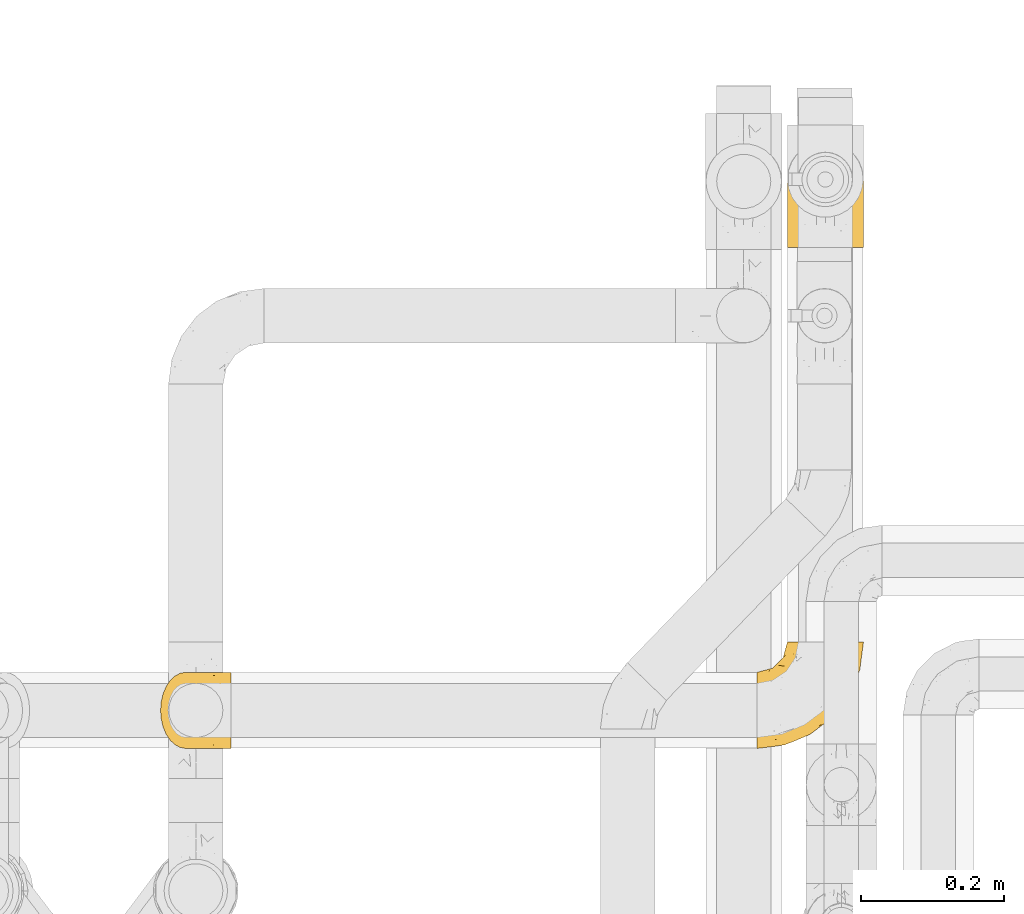
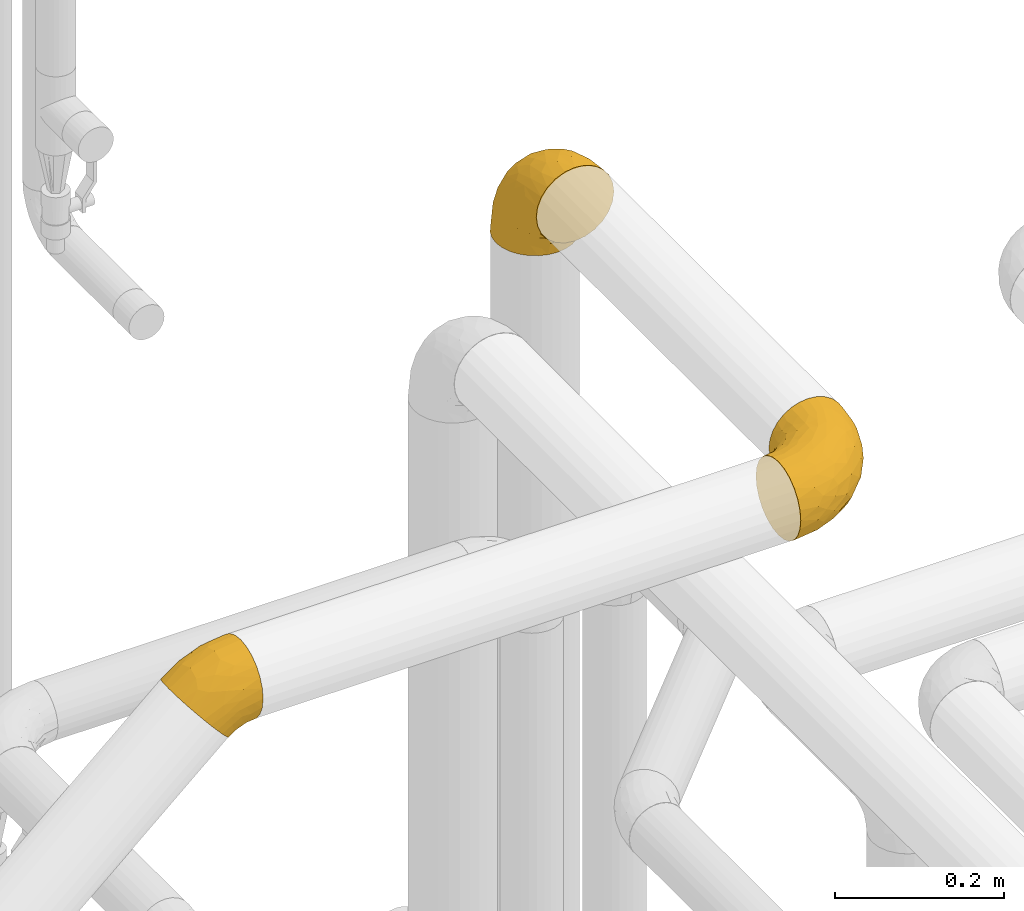
# One storey, part 396 of 827: 3 coverings.
"""IFC2X3 building model written with IfcOpenShell, lengths in millimetres."""

from ifc_helpers import new_model, entity, si_unit, converted_unit, derived_unit, direction, frame, origin, place, context, subcontext, project, spatial, faceted_brep, element, save


model = new_model("IFC2X3")

# Units and contexts
model_context = context("Model", 3, precision=0.01, world=origin(), true_north=direction((6.12303176911189e-17, 1.0)))
body_context = subcontext(model_context, "Body", "Model", "MODEL_VIEW")
ifc_project = project(units=[si_unit("LENGTHUNIT", "METRE", prefix="MILLI"), si_unit("AREAUNIT", "SQUARE_METRE"), si_unit("VOLUMEUNIT", "CUBIC_METRE"), converted_unit("PLANEANGLEUNIT", "DEGREE", entity("IfcRatioMeasure", 0.0174532925199433), si_unit("PLANEANGLEUNIT", "RADIAN"), dimensions=[0, 0, 0, 0, 0, 0, 0]), si_unit("MASSUNIT", "GRAM", prefix="KILO"), derived_unit("MASSDENSITYUNIT", [(si_unit("MASSUNIT", "GRAM", prefix="KILO"), 1), (si_unit("LENGTHUNIT", "METRE"), -3)]), derived_unit("MOMENTOFINERTIAUNIT", [(si_unit("LENGTHUNIT", "METRE"), 4)]), si_unit("TIMEUNIT", "SECOND"), si_unit("FREQUENCYUNIT", "HERTZ"), si_unit("THERMODYNAMICTEMPERATUREUNIT", "DEGREE_CELSIUS"), derived_unit("THERMALTRANSMITTANCEUNIT", [(si_unit("MASSUNIT", "GRAM", prefix="KILO"), 1), (si_unit("THERMODYNAMICTEMPERATUREUNIT", "KELVIN"), -1), (si_unit("TIMEUNIT", "SECOND"), -3)]), derived_unit("VOLUMETRICFLOWRATEUNIT", [(si_unit("LENGTHUNIT", "METRE"), 3), (si_unit("TIMEUNIT", "SECOND"), -1)]), derived_unit("MASSFLOWRATEUNIT", [(si_unit("MASSUNIT", "GRAM", prefix="KILO"), 1), (si_unit("TIMEUNIT", "SECOND"), -1)]), derived_unit("ROTATIONALFREQUENCYUNIT", [(si_unit("TIMEUNIT", "SECOND"), -1)]), si_unit("ELECTRICCURRENTUNIT", "AMPERE"), si_unit("ELECTRICVOLTAGEUNIT", "VOLT"), si_unit("POWERUNIT", "WATT"), si_unit("FORCEUNIT", "NEWTON", prefix="KILO"), si_unit("ILLUMINANCEUNIT", "LUX"), si_unit("LUMINOUSFLUXUNIT", "LUMEN"), si_unit("LUMINOUSINTENSITYUNIT", "CANDELA"), derived_unit("USERDEFINED", [(si_unit("MASSUNIT", "GRAM", prefix="KILO"), -1), (si_unit("LENGTHUNIT", "METRE"), -2), (si_unit("TIMEUNIT", "SECOND"), 3), (si_unit("LUMINOUSFLUXUNIT", "LUMEN"), 1)]), derived_unit("LINEARVELOCITYUNIT", [(si_unit("LENGTHUNIT", "METRE"), 1), (si_unit("TIMEUNIT", "SECOND"), -1)]), si_unit("PRESSUREUNIT", "PASCAL"), derived_unit("USERDEFINED", [(si_unit("LENGTHUNIT", "METRE"), -2), (si_unit("MASSUNIT", "GRAM", prefix="KILO"), 1), (si_unit("TIMEUNIT", "SECOND"), -2)]), derived_unit("LINEARFORCEUNIT", [(si_unit("MASSUNIT", "GRAM", prefix="KILO"), 1), (si_unit("LENGTHUNIT", "METRE"), 1), (si_unit("TIMEUNIT", "SECOND"), -2), (si_unit("LENGTHUNIT", "METRE"), -1)]), derived_unit("PLANARFORCEUNIT", [(si_unit("MASSUNIT", "GRAM", prefix="KILO"), 1), (si_unit("LENGTHUNIT", "METRE"), 1), (si_unit("TIMEUNIT", "SECOND"), -2), (si_unit("LENGTHUNIT", "METRE"), -2)])], contexts=[model_context])

# Site, building, storey
site_placement = place(None, origin())
site = spatial("IfcSite", under=ifc_project, at=site_placement, CompositionType="ELEMENT")
building_placement = place(site_placement, origin())
building = spatial("IfcBuilding", under=site, at=building_placement, CompositionType="ELEMENT")
storey_placement = place(building_placement, frame((0.0, 0.0, 28200.0)))
storey = spatial("IfcBuildingStorey", under=building, at=storey_placement, Name="08", CompositionType="ELEMENT", Elevation=28200.0)

# Coverings
covering_1_placement = place(storey_placement, frame((46573.97, 14483.43, 3345.35)))
element("IfcCovering", 1, at=covering_1_placement, inside=storey, Name=":ADSK_", ObjectType=":ADSK_", PredefinedType="INSULATION", context=body_context, shape_type="Brep", body=[
    faceted_brep([(148.32, 149.65, 66.44), (149.65, 149.65, 54.65), (148.31, 149.65, 42.84), (144.39, 149.65, 31.62), (138.06, 149.65, 21.56), (129.66, 149.65, 13.16), (119.6, 149.65, 6.84), (108.39, 149.65, 2.92), (96.6, 149.65, 1.6), (84.79, 149.65, 2.93), (73.57, 149.65, 6.85), (63.51, 149.65, 13.18), (55.11, 149.65, 21.58), (48.79, 149.65, 31.64), (44.87, 149.65, 42.85), (43.55, 149.65, 54.65), (44.88, 149.65, 66.46), (48.8, 149.65, 77.67), (55.13, 149.65, 87.73), (63.53, 149.65, 96.13), (73.59, 149.65, 102.45), (84.8, 149.65, 106.37), (96.6, 149.65, 107.7), (108.41, 149.65, 106.36), (119.62, 149.65, 102.44), (129.68, 149.65, 96.11), (138.08, 149.65, 87.71), (144.4, 149.65, 77.65), (1.6, 105.89, 40.91), (1.6, 100.59, 28.12), (1.6, 92.16, 17.13), (1.6, 81.17, 8.7), (1.6, 68.38, 3.4), (1.6, 54.65, 1.6), (1.6, 40.91, 3.4), (1.6, 28.12, 8.7), (1.6, 17.13, 17.13), (1.6, 8.7, 28.12), (1.6, 3.4, 40.91), (1.6, 1.6, 54.65), (1.6, 3.4, 68.38), (1.6, 8.7, 81.17), (1.6, 17.13, 92.16), (1.6, 28.12, 100.59), (1.6, 40.91, 105.89), (1.6, 54.65, 107.7), (1.6, 68.38, 105.89), (1.6, 81.17, 100.59), (1.6, 92.16, 92.16), (1.6, 100.59, 81.17), (1.6, 105.89, 68.38), (1.6, 107.7, 54.65), (27.97, 14.05, 85.53), (37.09, 9.45, 73.42), (58.27, 22.36, 83.77), (27.13, 4.7, 64.22), (39.91, 6.64, 54.65), (109.11, 81.47, 96.72), (94.41, 56.83, 93.36), (110.94, 64.02, 84.47), (89.69, 34.04, 71.37), (75.62, 21.43, 54.65), (106.28, 44.96, 54.65), (60.12, 49.8, 103.47), (41.41, 35.43, 100.91), (63.22, 42.1, 99.1), (32.05, 43.59, 105.43), (52.13, 57.88, 106.79), (123.27, 91.8, 89.81), (129.32, 88.01, 79.59), (138.3, 115.65, 81.29), (62.95, 18.94, 74.01), (55.89, 12.83, 64.14), (37.4, 24.96, 94.75), (144.6, 111.33, 54.65), (142.66, 113.8, 70.74), (117.85, 60.89, 68.3), (134.01, 86.24, 66.05), (89.25, 65.84, 100.73), (103.34, 124.58, 106.78), (113.52, 121.36, 103.6), (57.43, 72.79, 107.7), (44.19, 66.04, 107.7), (30.95, 59.29, 107.7), (77.98, 73.26, 106.07), (132.66, 121.69, 90.59), (121.52, 109.82, 97.43), (86.93, 40.11, 84.51), (68.4, 36.57, 93.3), (78.45, 93.81, 107.7), (67.94, 83.3, 107.7), (94.53, 136.6, 107.7), (91.95, 120.29, 107.7), (93.36, 99.11, 106.79), (85.2, 107.05, 107.7), (101.45, 91.12, 103.47), (129.81, 75.62, 54.65), (16.27, 56.97, 107.7), (42.46, 126.65, 76.99), (40.4, 116.55, 84.28), (49.71, 120.09, 91.11), (39.4, 76.06, 106.26), (31.26, 83.69, 102.6), (27.7, 71.88, 106.08), (16.7, 66.92, 106.56), (70.67, 110.43, 105.36), (81.69, 121.31, 106.74), (16.68, 81.0, 101.59), (22.57, 113.32, 54.65), (14.26, 111.09, 54.65), (17.68, 109.14, 67.71), (19.58, 95.86, 91.36), (33.49, 99.07, 94.33), (33.01, 106.92, 87.1), (40.69, 131.39, 65.84), (40.15, 136.98, 54.65), (37.93, 128.67, 54.65), (31.04, 117.07, 68.92), (45.29, 96.39, 100.82), (23.55, 106.61, 79.83), (11.36, 103.72, 77.13), (59.1, 92.14, 105.9), (57.42, 107.13, 101.53), (68.96, 98.03, 106.72), (20.38, 88.38, 97.75), (72.46, 130.66, 103.08), (83.66, 135.45, 106.39), (60.66, 123.57, 98.1), (61.01, 137.75, 95.02), (51.85, 133.2, 86.9), (46.07, 138.8, 74.42), (30.25, 120.99, 54.65), (46.65, 84.53, 105.28), (43.0, 108.72, 92.87), (19.58, 95.86, 17.93), (72.44, 130.67, 6.22), (17.67, 109.13, 41.58), (78.45, 93.81, 1.6), (68.97, 98.02, 2.57), (70.65, 110.43, 3.94), (40.69, 131.4, 43.46), (42.45, 126.66, 32.32), (31.04, 117.08, 40.38), (42.99, 108.74, 16.44), (45.18, 96.31, 8.47), (33.46, 99.11, 15.01), (60.64, 123.58, 11.21), (57.37, 107.12, 7.78), (57.43, 72.79, 1.6), (44.19, 66.04, 1.6), (39.35, 76.07, 3.04), (16.27, 56.97, 1.6), (16.7, 66.92, 2.73), (91.95, 120.29, 1.6), (85.2, 107.05, 1.6), (81.68, 121.26, 2.55), (46.68, 84.46, 3.98), (31.26, 83.69, 6.69), (16.68, 81.0, 7.7), (27.7, 71.88, 3.21), (60.99, 137.76, 14.28), (51.84, 133.21, 22.42), (40.41, 116.58, 25.02), (49.72, 120.1, 18.18), (46.06, 138.81, 34.89), (94.53, 136.6, 1.6), (11.35, 103.72, 32.17), (33.02, 106.96, 22.23), (83.65, 135.44, 2.91), (20.38, 88.38, 11.54), (67.94, 83.3, 1.6), (23.53, 106.6, 29.46), (59.12, 92.12, 3.38), (30.95, 59.29, 1.6), (58.27, 22.36, 25.52), (27.97, 14.05, 23.76), (37.4, 24.96, 14.54), (41.41, 35.43, 8.38), (27.21, 4.71, 45.07), (37.09, 9.45, 35.87), (53.2, 11.79, 45.14), (52.13, 57.88, 2.5), (103.34, 124.57, 2.51), (113.5, 121.37, 5.68), (101.45, 91.12, 5.82), (94.41, 56.83, 15.93), (109.08, 81.48, 12.54), (110.95, 64.05, 24.81), (93.36, 99.11, 2.5), (77.98, 73.26, 3.22), (32.05, 43.59, 3.86), (64.63, 19.5, 35.85), (123.25, 91.8, 19.47), (132.65, 121.7, 18.68), (129.32, 88.04, 29.68), (139.96, 123.34, 27.95), (117.85, 60.89, 40.99), (89.69, 34.04, 37.92), (121.51, 109.85, 11.85), (63.23, 42.1, 10.19), (89.17, 65.78, 8.55), (142.66, 113.81, 38.53), (68.4, 36.57, 15.99), (86.94, 40.12, 24.79), (60.12, 49.8, 5.82), (133.2, 86.08, 40.56)], [[[0, 1, 2, 3, 4, 5, 6, 7, 8, 9, 10, 11, 12, 13, 14, 15, 16, 17, 18, 19, 20, 21, 22, 23, 24, 25, 26, 27]], [[28, 29, 30, 31, 32, 33, 34, 35, 36, 37, 38, 39, 40, 41, 42, 43, 44, 45, 46, 47, 48, 49, 50, 51]], [[52, 53, 54]], [[55, 39, 56]], [[57, 58, 59]], [[60, 61, 62]], [[63, 64, 65]], [[66, 63, 67]], [[68, 69, 70]], [[53, 71, 54]], [[41, 40, 53]], [[53, 72, 71]], [[73, 42, 52]], [[42, 41, 52]], [[74, 0, 75]], [[69, 76, 77]], [[43, 73, 64]], [[45, 44, 66]], [[57, 78, 58]], [[23, 79, 80]], [[67, 81, 82, 83]], [[67, 84, 81]], [[24, 23, 80]], [[25, 85, 26]], [[86, 85, 25]], [[42, 73, 43]], [[0, 27, 75]], [[25, 24, 86]], [[70, 26, 85]], [[0, 74, 1]], [[68, 85, 86]], [[66, 64, 63]], [[60, 59, 87]], [[54, 87, 88]], [[76, 60, 62]], [[84, 89, 90, 81]], [[79, 22, 91, 92]], [[77, 74, 75]], [[93, 92, 94, 89]], [[80, 86, 24]], [[40, 55, 53]], [[76, 59, 60]], [[93, 84, 95]], [[76, 62, 96]], [[55, 72, 53]], [[70, 27, 26]], [[75, 70, 69]], [[78, 84, 63]], [[93, 79, 92]], [[95, 86, 80]], [[77, 76, 96]], [[59, 69, 68]], [[57, 68, 86]], [[68, 57, 59]], [[59, 58, 87]], [[76, 69, 59]], [[88, 87, 58]], [[87, 54, 71]], [[86, 95, 57]], [[78, 57, 95]], [[84, 78, 95]], [[78, 63, 65]], [[58, 78, 65]], [[54, 88, 73]], [[84, 93, 89]], [[79, 95, 80]], [[79, 93, 95]], [[22, 79, 23]], [[66, 83, 97, 45]], [[84, 67, 63]], [[83, 66, 67]], [[64, 44, 43]], [[64, 66, 44]], [[65, 73, 88]], [[53, 52, 41]], [[73, 52, 54]], [[73, 65, 64]], [[65, 88, 58]], [[39, 55, 40]], [[72, 55, 56]], [[56, 61, 72]], [[60, 72, 61]], [[72, 60, 71]], [[87, 71, 60]], [[27, 70, 75]], [[68, 70, 85]], [[74, 77, 96]], [[69, 77, 75]], [[98, 99, 100]], [[46, 45, 97]], [[101, 102, 103]], [[103, 104, 83]], [[105, 94, 106]], [[107, 103, 102]], [[108, 109, 51, 110]], [[111, 112, 113]], [[114, 115, 116]], [[47, 104, 107]], [[110, 117, 108]], [[49, 48, 111]], [[102, 118, 112]], [[119, 120, 111]], [[50, 49, 120]], [[121, 122, 118]], [[105, 123, 89]], [[124, 48, 107]], [[20, 19, 125]], [[121, 81, 90]], [[117, 119, 99]], [[21, 20, 126]], [[22, 21, 91]], [[105, 125, 127]], [[110, 51, 50]], [[19, 128, 125]], [[16, 15, 115]], [[129, 98, 100]], [[126, 91, 21]], [[128, 129, 127]], [[122, 123, 105]], [[114, 117, 98]], [[17, 16, 130]], [[18, 128, 19]], [[129, 18, 17]], [[125, 106, 126]], [[115, 114, 16]], [[130, 129, 17]], [[114, 98, 130]], [[117, 116, 131, 108]], [[99, 119, 113]], [[122, 121, 123]], [[92, 126, 106]], [[105, 127, 122]], [[132, 121, 118]], [[114, 130, 16]], [[129, 130, 98]], [[50, 120, 110]], [[129, 128, 18]], [[125, 128, 127]], [[125, 126, 20]], [[91, 126, 92]], [[105, 89, 94]], [[105, 106, 125]], [[94, 92, 106]], [[100, 122, 127]], [[118, 122, 133]], [[112, 118, 133]], [[132, 118, 102]], [[132, 102, 101]], [[81, 121, 132]], [[82, 103, 83]], [[132, 101, 81]], [[104, 47, 46]], [[124, 107, 102]], [[48, 47, 107]], [[113, 112, 133]], [[112, 111, 124]], [[99, 113, 133]], [[111, 113, 119]], [[99, 133, 100]], [[117, 99, 98]], [[122, 100, 133]], [[127, 129, 100]], [[103, 82, 101]], [[81, 101, 82]], [[112, 124, 102]], [[48, 124, 111]], [[104, 103, 107]], [[46, 97, 104]], [[111, 120, 49]], [[83, 104, 97]], [[110, 120, 119]], [[117, 110, 119]], [[116, 117, 114]], [[89, 123, 90]], [[90, 123, 121]], [[30, 29, 134]], [[11, 10, 135]], [[51, 109, 108, 136]], [[137, 138, 139]], [[140, 141, 142]], [[143, 144, 145]], [[146, 139, 147]], [[148, 149, 150]], [[151, 32, 152]], [[153, 154, 155]], [[156, 150, 157]], [[158, 157, 159]], [[108, 142, 136]], [[31, 158, 152]], [[160, 161, 12]], [[162, 163, 143]], [[140, 142, 116]], [[142, 141, 162]], [[14, 164, 140]], [[14, 140, 115]], [[9, 8, 165]], [[160, 12, 11]], [[141, 164, 161]], [[13, 12, 161]], [[14, 115, 15]], [[28, 166, 29]], [[135, 139, 146]], [[141, 163, 162]], [[135, 146, 160]], [[143, 167, 162]], [[29, 166, 134]], [[116, 142, 108, 131]], [[165, 153, 168]], [[10, 9, 168]], [[168, 135, 10]], [[138, 147, 139]], [[158, 169, 157]], [[14, 13, 164]], [[116, 115, 140]], [[145, 167, 143]], [[135, 160, 11]], [[168, 153, 155]], [[138, 137, 170]], [[157, 144, 156]], [[147, 144, 143]], [[161, 164, 13]], [[140, 164, 141]], [[142, 171, 136]], [[136, 171, 166]], [[161, 160, 146]], [[165, 168, 9]], [[155, 139, 135]], [[139, 154, 137]], [[168, 155, 135]], [[139, 155, 154]], [[144, 147, 172]], [[163, 147, 143]], [[156, 144, 172]], [[157, 169, 145]], [[172, 148, 156]], [[173, 159, 149]], [[159, 157, 150]], [[152, 159, 173]], [[159, 152, 158]], [[31, 30, 158]], [[169, 30, 134]], [[157, 145, 144]], [[167, 134, 171]], [[134, 167, 145]], [[171, 142, 162]], [[162, 167, 171]], [[163, 141, 161]], [[161, 146, 163]], [[147, 163, 146]], [[148, 150, 156]], [[149, 159, 150]], [[30, 169, 158]], [[145, 169, 134]], [[151, 33, 32]], [[31, 152, 32]], [[152, 173, 151]], [[28, 51, 136]], [[134, 166, 171]], [[28, 136, 166]], [[138, 170, 172]], [[147, 138, 172]], [[148, 172, 170]], [[174, 175, 176]], [[35, 34, 177]], [[178, 179, 180]], [[181, 173, 149, 148]], [[182, 183, 184]], [[185, 186, 187]], [[188, 189, 137]], [[190, 33, 151, 173]], [[191, 179, 174]], [[34, 190, 177]], [[39, 38, 178]], [[192, 193, 194]], [[4, 3, 195]], [[175, 179, 37]], [[38, 37, 179]], [[35, 176, 36]], [[196, 62, 197]], [[181, 190, 173]], [[37, 36, 175]], [[183, 6, 198]], [[189, 148, 170, 137]], [[185, 199, 200]], [[3, 2, 201]], [[202, 185, 203]], [[8, 7, 182]], [[200, 184, 186]], [[183, 7, 6]], [[181, 189, 204]], [[200, 189, 184]], [[5, 198, 6]], [[187, 203, 185]], [[195, 3, 201]], [[205, 196, 194]], [[62, 61, 197]], [[186, 198, 192]], [[180, 179, 191]], [[2, 1, 74]], [[198, 193, 192]], [[193, 5, 4]], [[194, 193, 195]], [[2, 74, 201]], [[5, 193, 198]], [[205, 74, 96]], [[188, 137, 154, 153]], [[62, 196, 96]], [[56, 178, 180]], [[198, 184, 183]], [[184, 188, 182]], [[203, 197, 191]], [[205, 194, 201]], [[187, 192, 194]], [[192, 187, 186]], [[194, 196, 187]], [[197, 187, 196]], [[197, 203, 187]], [[202, 174, 176]], [[200, 186, 185]], [[184, 198, 186]], [[199, 185, 202]], [[189, 200, 204]], [[174, 202, 203]], [[176, 177, 199]], [[189, 181, 148]], [[190, 181, 204]], [[190, 204, 177]], [[190, 34, 33]], [[188, 153, 182]], [[189, 188, 184]], [[182, 153, 165, 8]], [[183, 182, 7]], [[199, 177, 204]], [[35, 177, 176]], [[176, 175, 36]], [[179, 175, 174]], [[200, 199, 204]], [[176, 199, 202]], [[203, 191, 174]], [[180, 197, 61]], [[197, 180, 191]], [[61, 56, 180]], [[39, 178, 56]], [[38, 179, 178]], [[194, 195, 201]], [[4, 195, 193]], [[74, 205, 201]], [[96, 196, 205]]]),
])
covering_2_placement = place(storey_placement, frame((46615.92, 15181.48, 3303.4)))
element("IfcCovering", 2, at=covering_2_placement, inside=storey, Name=":ADSK_", ObjectType=":ADSK_", PredefinedType="INSULATION", context=body_context, shape_type="Brep", body=[
    faceted_brep([(42.85, 148.32, 1.6), (54.65, 149.65, 1.6), (66.46, 148.31, 1.6), (77.67, 144.39, 1.6), (87.73, 138.06, 1.6), (96.13, 129.66, 1.6), (102.45, 119.6, 1.6), (106.37, 108.39, 1.6), (107.7, 96.6, 1.6), (106.36, 84.79, 1.6), (102.44, 73.57, 1.6), (96.11, 63.51, 1.6), (87.71, 55.11, 1.6), (77.65, 48.79, 1.6), (66.44, 44.87, 1.6), (54.65, 43.55, 1.6), (42.84, 44.88, 1.6), (31.62, 48.8, 1.6), (21.56, 55.13, 1.6), (13.16, 63.53, 1.6), (6.84, 73.59, 1.6), (2.92, 84.8, 1.6), (1.6, 96.6, 1.6), (2.93, 108.41, 1.6), (6.85, 119.62, 1.6), (13.18, 129.68, 1.6), (21.58, 138.08, 1.6), (31.64, 144.4, 1.6), (68.38, 1.6, 45.35), (81.17, 1.6, 50.65), (92.16, 1.6, 59.08), (100.59, 1.6, 70.07), (105.89, 1.6, 82.86), (107.7, 1.6, 96.6), (105.89, 1.6, 110.33), (100.59, 1.6, 123.12), (92.16, 1.6, 134.11), (81.17, 1.6, 142.54), (68.38, 1.6, 147.84), (54.65, 1.6, 149.65), (40.91, 1.6, 147.84), (28.12, 1.6, 142.54), (17.13, 1.6, 134.11), (8.7, 1.6, 123.12), (3.4, 1.6, 110.33), (1.6, 1.6, 96.6), (3.4, 1.6, 82.86), (8.7, 1.6, 70.07), (17.13, 1.6, 59.08), (28.12, 1.6, 50.65), (40.91, 1.6, 45.35), (54.65, 1.6, 43.55), (23.76, 27.97, 137.19), (35.87, 37.09, 141.79), (25.52, 58.27, 128.89), (45.07, 27.13, 146.54), (54.65, 39.91, 144.6), (12.57, 109.11, 69.77), (15.93, 94.41, 94.41), (24.82, 110.94, 87.22), (37.92, 89.69, 117.2), (54.65, 75.62, 129.81), (54.65, 106.28, 106.28), (5.82, 60.12, 101.45), (8.38, 41.41, 115.81), (10.19, 63.22, 109.14), (3.86, 32.05, 107.65), (2.5, 52.13, 93.36), (19.48, 123.27, 59.44), (29.7, 129.32, 63.23), (28.0, 138.3, 35.59), (35.28, 62.95, 132.3), (45.15, 55.89, 138.41), (14.54, 37.4, 126.28), (54.65, 144.6, 39.91), (38.55, 142.66, 37.44), (40.99, 117.85, 90.35), (43.24, 134.01, 65.0), (8.56, 89.25, 85.4), (2.51, 103.34, 26.66), (5.69, 113.52, 29.88), (1.6, 57.43, 78.45), (1.6, 44.19, 85.2), (1.6, 30.95, 91.95), (3.22, 77.98, 77.98), (18.7, 132.66, 29.55), (11.86, 121.52, 41.42), (24.78, 86.93, 111.13), (15.99, 68.4, 114.67), (1.6, 78.45, 57.43), (1.6, 67.94, 67.94), (1.6, 94.53, 14.64), (1.6, 91.95, 30.95), (2.5, 93.36, 52.13), (1.6, 85.2, 44.19), (5.82, 101.45, 60.12), (54.65, 129.81, 75.62), (1.6, 16.27, 94.27), (32.3, 42.46, 24.59), (25.01, 40.4, 34.69), (18.18, 49.71, 31.15), (3.03, 39.4, 75.18), (6.69, 31.26, 67.55), (3.21, 27.7, 79.36), (2.73, 16.7, 84.32), (3.93, 70.67, 40.81), (2.55, 81.69, 29.93), (7.7, 16.68, 70.24), (54.65, 22.57, 37.93), (54.65, 14.26, 40.15), (41.58, 17.68, 42.1), (17.93, 19.58, 55.38), (14.97, 33.49, 52.17), (22.2, 33.01, 44.32), (43.45, 40.69, 19.85), (54.65, 40.15, 14.26), (54.65, 37.93, 22.57), (40.37, 31.04, 34.17), (8.47, 45.29, 54.85), (29.46, 23.55, 44.63), (32.17, 11.36, 47.52), (3.39, 59.1, 59.1), (7.76, 57.42, 44.11), (2.57, 68.96, 53.21), (11.54, 20.38, 62.86), (6.21, 72.46, 20.58), (2.9, 83.66, 15.79), (11.19, 60.66, 27.67), (14.27, 61.01, 13.49), (22.4, 51.85, 18.04), (34.87, 46.07, 12.44), (54.65, 30.25, 30.25), (4.01, 46.65, 66.71), (16.42, 43.0, 42.52), (91.36, 19.58, 55.38), (103.07, 72.44, 20.57), (67.71, 17.67, 42.11), (107.7, 78.45, 57.43), (106.72, 68.97, 53.22), (105.35, 70.65, 40.81), (65.83, 40.69, 19.85), (76.97, 42.45, 24.58), (68.91, 31.04, 34.16), (92.85, 42.99, 42.5), (100.82, 45.18, 54.93), (94.28, 33.46, 52.13), (98.08, 60.64, 27.66), (101.51, 57.37, 44.12), (107.7, 57.43, 78.45), (107.7, 44.19, 85.2), (106.25, 39.35, 75.17), (107.7, 16.27, 94.27), (106.56, 16.7, 84.32), (107.7, 91.95, 30.95), (107.7, 85.2, 44.19), (106.74, 81.68, 29.98), (105.31, 46.68, 66.78), (102.6, 31.26, 67.55), (101.59, 16.68, 70.24), (106.08, 27.7, 79.36), (95.01, 60.99, 13.48), (86.87, 51.84, 18.03), (84.27, 40.41, 34.66), (91.11, 49.72, 31.14), (74.4, 46.06, 12.43), (107.7, 94.53, 14.64), (77.12, 11.35, 47.52), (87.06, 33.02, 44.28), (106.38, 83.65, 15.8), (97.75, 20.38, 62.86), (107.7, 67.94, 67.94), (79.83, 23.53, 44.64), (105.91, 59.12, 59.12), (107.7, 30.95, 91.95), (83.77, 58.27, 128.89), (85.53, 27.97, 137.19), (94.75, 37.4, 126.28), (100.91, 41.41, 115.81), (64.22, 27.21, 146.53), (73.42, 37.09, 141.79), (64.15, 53.2, 139.45), (106.79, 52.13, 93.36), (106.79, 103.34, 26.67), (103.61, 113.5, 29.87), (103.47, 101.45, 60.12), (93.36, 94.41, 94.41), (96.75, 109.08, 69.76), (84.48, 110.95, 87.19), (106.79, 93.36, 52.13), (106.07, 77.98, 77.98), (105.43, 32.05, 107.65), (73.44, 64.63, 131.74), (89.82, 123.25, 59.44), (90.61, 132.65, 29.54), (79.61, 129.32, 63.2), (81.34, 139.96, 27.9), (68.3, 117.85, 90.35), (71.37, 89.69, 117.2), (97.44, 121.51, 41.39), (99.1, 63.23, 109.14), (100.74, 89.17, 85.46), (70.76, 142.66, 37.43), (93.3, 68.4, 114.67), (84.5, 86.94, 111.12), (103.47, 60.12, 101.45), (68.73, 133.2, 65.16)], [[[0, 1, 2, 3, 4, 5, 6, 7, 8, 9, 10, 11, 12, 13, 14, 15, 16, 17, 18, 19, 20, 21, 22, 23, 24, 25, 26, 27]], [[28, 29, 30, 31, 32, 33, 34, 35, 36, 37, 38, 39, 40, 41, 42, 43, 44, 45, 46, 47, 48, 49, 50, 51]], [[52, 53, 54]], [[55, 39, 56]], [[57, 58, 59]], [[60, 61, 62]], [[63, 64, 65]], [[66, 63, 67]], [[68, 69, 70]], [[53, 71, 54]], [[41, 40, 53]], [[53, 72, 71]], [[73, 42, 52]], [[42, 41, 52]], [[74, 0, 75]], [[69, 76, 77]], [[43, 73, 64]], [[45, 44, 66]], [[57, 78, 58]], [[23, 79, 80]], [[67, 81, 82, 83]], [[67, 84, 81]], [[24, 23, 80]], [[25, 85, 26]], [[86, 85, 25]], [[42, 73, 43]], [[0, 27, 75]], [[25, 24, 86]], [[70, 26, 85]], [[0, 74, 1]], [[68, 85, 86]], [[66, 64, 63]], [[60, 59, 87]], [[54, 87, 88]], [[76, 60, 62]], [[84, 89, 90, 81]], [[79, 22, 91, 92]], [[77, 74, 75]], [[93, 92, 94, 89]], [[80, 86, 24]], [[40, 55, 53]], [[76, 59, 60]], [[93, 84, 95]], [[76, 62, 96]], [[55, 72, 53]], [[70, 27, 26]], [[75, 70, 69]], [[78, 84, 63]], [[93, 79, 92]], [[95, 86, 80]], [[77, 76, 96]], [[59, 69, 68]], [[57, 68, 86]], [[68, 57, 59]], [[59, 58, 87]], [[76, 69, 59]], [[88, 87, 58]], [[87, 54, 71]], [[86, 95, 57]], [[78, 57, 95]], [[84, 78, 95]], [[78, 63, 65]], [[58, 78, 65]], [[54, 88, 73]], [[84, 93, 89]], [[79, 95, 80]], [[79, 93, 95]], [[22, 79, 23]], [[66, 83, 97, 45]], [[84, 67, 63]], [[83, 66, 67]], [[64, 44, 43]], [[64, 66, 44]], [[65, 73, 88]], [[53, 52, 41]], [[73, 52, 54]], [[73, 65, 64]], [[65, 88, 58]], [[39, 55, 40]], [[72, 55, 56]], [[56, 61, 72]], [[60, 72, 61]], [[72, 60, 71]], [[87, 71, 60]], [[27, 70, 75]], [[68, 70, 85]], [[74, 77, 96]], [[69, 77, 75]], [[98, 99, 100]], [[46, 45, 97]], [[101, 102, 103]], [[103, 104, 83]], [[105, 94, 106]], [[107, 103, 102]], [[108, 109, 51, 110]], [[111, 112, 113]], [[114, 115, 116]], [[47, 104, 107]], [[110, 117, 108]], [[49, 48, 111]], [[102, 118, 112]], [[119, 120, 111]], [[50, 49, 120]], [[121, 122, 118]], [[105, 123, 89]], [[124, 48, 107]], [[20, 19, 125]], [[121, 81, 90]], [[117, 119, 99]], [[21, 20, 126]], [[22, 21, 91]], [[105, 125, 127]], [[110, 51, 50]], [[19, 128, 125]], [[16, 15, 115]], [[129, 98, 100]], [[126, 91, 21]], [[128, 129, 127]], [[122, 123, 105]], [[114, 117, 98]], [[17, 16, 130]], [[18, 128, 19]], [[129, 18, 17]], [[125, 106, 126]], [[115, 114, 16]], [[130, 129, 17]], [[114, 98, 130]], [[117, 116, 131, 108]], [[99, 119, 113]], [[122, 121, 123]], [[92, 126, 106]], [[105, 127, 122]], [[132, 121, 118]], [[114, 130, 16]], [[129, 130, 98]], [[50, 120, 110]], [[129, 128, 18]], [[125, 128, 127]], [[125, 126, 20]], [[91, 126, 92]], [[105, 89, 94]], [[105, 106, 125]], [[94, 92, 106]], [[100, 122, 127]], [[118, 122, 133]], [[112, 118, 133]], [[132, 118, 102]], [[132, 102, 101]], [[81, 121, 132]], [[82, 103, 83]], [[132, 101, 81]], [[104, 47, 46]], [[124, 107, 102]], [[48, 47, 107]], [[113, 112, 133]], [[112, 111, 124]], [[99, 113, 133]], [[111, 113, 119]], [[99, 133, 100]], [[117, 99, 98]], [[122, 100, 133]], [[127, 129, 100]], [[103, 82, 101]], [[81, 101, 82]], [[112, 124, 102]], [[48, 124, 111]], [[104, 103, 107]], [[46, 97, 104]], [[111, 120, 49]], [[83, 104, 97]], [[110, 120, 119]], [[117, 110, 119]], [[116, 117, 114]], [[89, 123, 90]], [[90, 123, 121]], [[30, 29, 134]], [[11, 10, 135]], [[51, 109, 108, 136]], [[137, 138, 139]], [[140, 141, 142]], [[143, 144, 145]], [[146, 139, 147]], [[148, 149, 150]], [[151, 32, 152]], [[153, 154, 155]], [[156, 150, 157]], [[158, 157, 159]], [[108, 142, 136]], [[31, 158, 152]], [[160, 161, 12]], [[162, 163, 143]], [[140, 142, 116]], [[142, 141, 162]], [[14, 164, 140]], [[14, 140, 115]], [[9, 8, 165]], [[160, 12, 11]], [[141, 164, 161]], [[13, 12, 161]], [[14, 115, 15]], [[28, 166, 29]], [[135, 139, 146]], [[141, 163, 162]], [[135, 146, 160]], [[143, 167, 162]], [[29, 166, 134]], [[116, 142, 108, 131]], [[165, 153, 168]], [[10, 9, 168]], [[168, 135, 10]], [[138, 147, 139]], [[158, 169, 157]], [[14, 13, 164]], [[116, 115, 140]], [[145, 167, 143]], [[135, 160, 11]], [[168, 153, 155]], [[138, 137, 170]], [[157, 144, 156]], [[147, 144, 143]], [[161, 164, 13]], [[140, 164, 141]], [[142, 171, 136]], [[136, 171, 166]], [[161, 160, 146]], [[165, 168, 9]], [[155, 139, 135]], [[139, 154, 137]], [[168, 155, 135]], [[139, 155, 154]], [[144, 147, 172]], [[163, 147, 143]], [[156, 144, 172]], [[157, 169, 145]], [[172, 148, 156]], [[173, 159, 149]], [[159, 157, 150]], [[152, 159, 173]], [[159, 152, 158]], [[31, 30, 158]], [[169, 30, 134]], [[157, 145, 144]], [[167, 134, 171]], [[134, 167, 145]], [[171, 142, 162]], [[162, 167, 171]], [[163, 141, 161]], [[161, 146, 163]], [[147, 163, 146]], [[148, 150, 156]], [[149, 159, 150]], [[30, 169, 158]], [[145, 169, 134]], [[151, 33, 32]], [[31, 152, 32]], [[152, 173, 151]], [[28, 51, 136]], [[134, 166, 171]], [[28, 136, 166]], [[138, 170, 172]], [[147, 138, 172]], [[148, 172, 170]], [[174, 175, 176]], [[35, 34, 177]], [[178, 179, 180]], [[181, 173, 149, 148]], [[182, 183, 184]], [[185, 186, 187]], [[188, 189, 137]], [[190, 33, 151, 173]], [[191, 179, 174]], [[34, 190, 177]], [[39, 38, 178]], [[192, 193, 194]], [[4, 3, 195]], [[175, 179, 37]], [[38, 37, 179]], [[35, 176, 36]], [[196, 62, 197]], [[181, 190, 173]], [[37, 36, 175]], [[183, 6, 198]], [[189, 148, 170, 137]], [[185, 199, 200]], [[3, 2, 201]], [[202, 185, 203]], [[8, 7, 182]], [[200, 184, 186]], [[183, 7, 6]], [[181, 189, 204]], [[200, 189, 184]], [[5, 198, 6]], [[187, 203, 185]], [[195, 3, 201]], [[205, 196, 194]], [[62, 61, 197]], [[186, 198, 192]], [[180, 179, 191]], [[2, 1, 74]], [[198, 193, 192]], [[193, 5, 4]], [[194, 193, 195]], [[2, 74, 201]], [[5, 193, 198]], [[205, 74, 96]], [[188, 137, 154, 153]], [[62, 196, 96]], [[56, 178, 180]], [[198, 184, 183]], [[184, 188, 182]], [[203, 197, 191]], [[205, 194, 201]], [[187, 192, 194]], [[192, 187, 186]], [[194, 196, 187]], [[197, 187, 196]], [[197, 203, 187]], [[202, 174, 176]], [[200, 186, 185]], [[184, 198, 186]], [[199, 185, 202]], [[189, 200, 204]], [[174, 202, 203]], [[176, 177, 199]], [[189, 181, 148]], [[190, 181, 204]], [[190, 204, 177]], [[190, 34, 33]], [[188, 153, 182]], [[189, 188, 184]], [[182, 153, 165, 8]], [[183, 182, 7]], [[199, 177, 204]], [[35, 177, 176]], [[176, 175, 36]], [[179, 175, 174]], [[200, 199, 204]], [[176, 199, 202]], [[203, 191, 174]], [[180, 197, 61]], [[197, 180, 191]], [[61, 56, 180]], [[39, 178, 56]], [[38, 179, 178]], [[194, 195, 201]], [[4, 195, 193]], [[74, 205, 201]], [[96, 196, 205]]]),
])
covering_3_placement = place(storey_placement, frame((45742.34, 14483.43, 3334.87)))
element("IfcCovering", 3, at=covering_3_placement, inside=storey, Name=":ADSK_", ObjectType=":ADSK_", PredefinedType="INSULATION", context=body_context, shape_type="Brep", body=[
    faceted_brep([(70.88, 42.84, 2.59), (68.28, 31.62, 5.54), (64.1, 21.56, 10.28), (58.54, 13.16, 16.59), (51.89, 6.84, 24.13), (44.48, 2.92, 32.54), (36.68, 1.6, 41.39), (28.87, 2.93, 50.25), (21.45, 6.85, 58.66), (14.8, 13.18, 66.21), (9.24, 21.58, 72.51), (5.07, 31.64, 77.25), (2.47, 42.85, 80.19), (1.6, 54.65, 81.18), (2.48, 66.46, 80.19), (5.07, 77.67, 77.24), (9.25, 87.73, 72.5), (14.81, 96.13, 66.19), (21.46, 102.45, 58.65), (28.88, 106.37, 50.24), (36.68, 107.7, 41.39), (44.49, 106.36, 32.53), (51.9, 102.44, 24.12), (58.55, 96.11, 16.57), (64.11, 87.71, 10.27), (68.29, 77.65, 5.53), (70.88, 66.44, 2.59), (71.76, 54.65, 1.6), (99.5, 68.38, 13.88), (99.5, 81.17, 19.18), (99.5, 92.16, 27.61), (99.5, 100.59, 38.6), (99.5, 105.89, 51.4), (99.5, 107.7, 65.13), (99.5, 105.89, 78.86), (99.5, 100.59, 91.65), (99.5, 92.16, 102.64), (99.5, 81.17, 111.07), (99.5, 68.38, 116.37), (99.5, 54.65, 118.18), (99.5, 40.91, 116.37), (99.5, 28.12, 111.07), (99.5, 17.13, 102.64), (99.5, 8.7, 91.65), (99.5, 3.4, 78.86), (99.5, 1.6, 65.13), (99.5, 3.4, 51.4), (99.5, 8.7, 38.6), (99.5, 17.13, 27.61), (99.5, 28.12, 19.18), (99.5, 40.91, 13.88), (99.5, 54.65, 12.08), (35.28, 17.9, 86.9), (64.19, 54.65, 113.9), (48.9, 27.61, 101.36), (65.17, 18.34, 99.33), (74.35, 25.86, 107.4), (62.85, 39.77, 111.37), (28.9, 37.7, 97.09), (65.92, 1.6, 58.99), (69.6, 2.76, 71.88), (48.95, 2.18, 59.7), (54.34, 10.82, 86.57), (48.17, 5.11, 71.92), (74.81, 6.14, 83.97), (30.91, 54.65, 101.33), (24.92, 26.97, 88.91), (47.98, 1.6, 48.19), (56.95, 1.6, 53.59), (76.22, 1.6, 60.88), (86.52, 1.6, 62.76), (80.75, 24.19, 18.17), (84.79, 15.45, 27.52), (87.13, 9.17, 36.66), (73.72, 6.96, 37.09), (79.69, 45.64, 7.98), (80.2, 35.85, 11.21), (85.1, 4.36, 46.9), (63.22, 8.38, 28.88), (58.84, 3.33, 40.82), (90.18, 45.83, 11.79), (71.27, 15.38, 22.31), (89.29, 31.4, 16.33), (71.65, 2.96, 48.36), (84.67, 54.65, 9.37), (84.8, 93.82, 27.5), (80.76, 85.08, 18.15), (71.28, 93.89, 22.29), (73.73, 102.32, 37.07), (63.23, 100.9, 28.86), (58.86, 105.96, 40.81), (80.2, 73.42, 11.21), (56.95, 107.7, 53.59), (65.92, 107.7, 58.99), (71.63, 106.33, 48.34), (89.3, 77.87, 16.32), (88.4, 65.16, 11.67), (85.09, 104.93, 46.9), (86.52, 107.7, 62.76), (86.33, 100.21, 36.67), (79.08, 62.8, 7.49), (76.22, 107.7, 60.88), (47.98, 107.7, 48.19), (73.23, 106.63, 72.41), (48.18, 104.18, 71.9), (74.82, 103.15, 83.96), (65.17, 90.96, 99.31), (35.29, 91.4, 86.89), (74.36, 83.45, 107.39), (48.91, 81.69, 101.35), (54.35, 98.48, 86.56), (50.2, 106.96, 61.47), (62.85, 69.55, 111.36), (28.91, 71.61, 97.09), (24.92, 82.34, 88.9)], [[[0, 1, 2, 3, 4, 5, 6, 7, 8, 9, 10, 11, 12, 13, 14, 15, 16, 17, 18, 19, 20, 21, 22, 23, 24, 25, 26, 27]], [[28, 29, 30, 31, 32, 33, 34, 35, 36, 37, 38, 39, 40, 41, 42, 43, 44, 45, 46, 47, 48, 49, 50, 51]], [[9, 52, 10]], [[40, 39, 53]], [[54, 55, 56]], [[57, 58, 54]], [[55, 43, 42]], [[57, 54, 56]], [[59, 60, 61]], [[62, 63, 64]], [[60, 45, 44]], [[62, 64, 43]], [[41, 40, 57]], [[55, 52, 62]], [[54, 52, 55]], [[60, 44, 64]], [[58, 57, 65]], [[65, 12, 58]], [[11, 10, 66]], [[11, 66, 58]], [[61, 63, 7]], [[13, 12, 65]], [[9, 62, 52]], [[44, 43, 64]], [[40, 53, 57]], [[61, 6, 67, 68, 59]], [[8, 7, 63]], [[8, 63, 62]], [[56, 42, 41]], [[43, 55, 62]], [[8, 62, 9]], [[65, 57, 53]], [[60, 64, 63]], [[11, 58, 12]], [[60, 59, 69, 70, 45]], [[66, 52, 54]], [[52, 66, 10]], [[58, 66, 54]], [[63, 61, 60]], [[6, 61, 7]], [[42, 56, 55]], [[57, 56, 41]], [[71, 49, 72]], [[73, 74, 72]], [[75, 76, 0]], [[1, 71, 2]], [[73, 47, 77]], [[67, 6, 5]], [[78, 79, 4]], [[75, 80, 76]], [[78, 81, 74]], [[51, 50, 80]], [[82, 71, 76]], [[71, 72, 81]], [[74, 77, 83]], [[77, 69, 83]], [[2, 71, 81]], [[83, 68, 79]], [[82, 50, 49]], [[5, 4, 79]], [[46, 70, 77]], [[46, 45, 70]], [[77, 47, 46]], [[84, 75, 27]], [[79, 67, 5]], [[0, 76, 1]], [[2, 81, 3]], [[48, 72, 49]], [[1, 76, 71]], [[79, 74, 83]], [[79, 78, 74]], [[78, 4, 3]], [[73, 48, 47]], [[81, 78, 3]], [[74, 81, 72]], [[82, 76, 80]], [[27, 75, 0]], [[69, 77, 70]], [[69, 59, 83]], [[49, 71, 82]], [[68, 83, 59]], [[68, 67, 79]], [[80, 75, 84]], [[51, 80, 84]], [[80, 50, 82]], [[74, 73, 77]], [[48, 73, 72]], [[85, 86, 87]], [[88, 89, 90]], [[26, 25, 91]], [[24, 23, 87]], [[92, 93, 94]], [[95, 28, 96]], [[97, 32, 31]], [[98, 33, 32]], [[85, 88, 99]], [[85, 99, 30]], [[91, 95, 96]], [[89, 87, 23]], [[51, 84, 96]], [[87, 88, 85]], [[27, 26, 100]], [[97, 94, 101]], [[91, 25, 86]], [[22, 21, 90]], [[94, 97, 88]], [[24, 86, 25]], [[24, 87, 86]], [[29, 86, 85]], [[21, 20, 102]], [[95, 91, 86]], [[90, 92, 94]], [[21, 102, 90]], [[85, 30, 29]], [[89, 23, 22]], [[90, 89, 22]], [[96, 100, 91]], [[87, 89, 88]], [[98, 32, 97]], [[88, 97, 99]], [[90, 94, 88]], [[101, 98, 97]], [[94, 93, 101]], [[86, 29, 95]], [[28, 95, 29]], [[90, 102, 92]], [[51, 96, 28]], [[100, 96, 84]], [[27, 100, 84]], [[91, 100, 26]], [[97, 31, 99]], [[30, 99, 31]], [[103, 104, 105]], [[35, 106, 36]], [[103, 33, 98, 101, 93]], [[17, 16, 107]], [[108, 106, 109]], [[106, 110, 107]], [[39, 38, 53]], [[103, 93, 111]], [[112, 109, 113]], [[103, 105, 34]], [[110, 106, 35]], [[37, 108, 112]], [[33, 103, 34]], [[108, 36, 106]], [[18, 104, 19]], [[35, 105, 110]], [[110, 104, 18]], [[65, 112, 113]], [[17, 110, 18]], [[105, 104, 110]], [[104, 103, 111]], [[107, 110, 17]], [[37, 112, 38]], [[114, 16, 15]], [[14, 13, 65]], [[112, 65, 53]], [[14, 65, 113]], [[114, 113, 109]], [[114, 107, 16]], [[14, 113, 15]], [[106, 107, 109]], [[111, 20, 19]], [[53, 38, 112]], [[105, 35, 34]], [[113, 114, 15]], [[107, 114, 109]], [[111, 93, 92, 102, 20]], [[104, 111, 19]], [[112, 108, 109]], [[36, 108, 37]]]),
])

save(model, "model.ifc")
